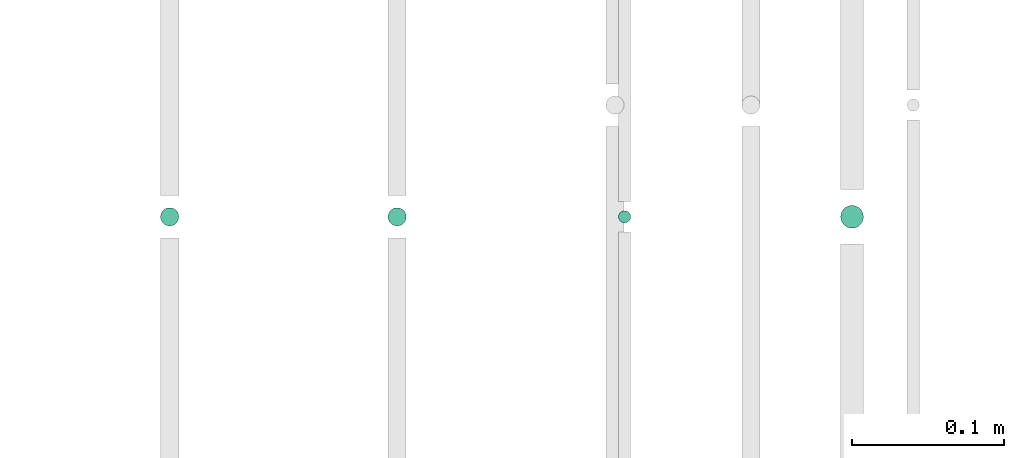
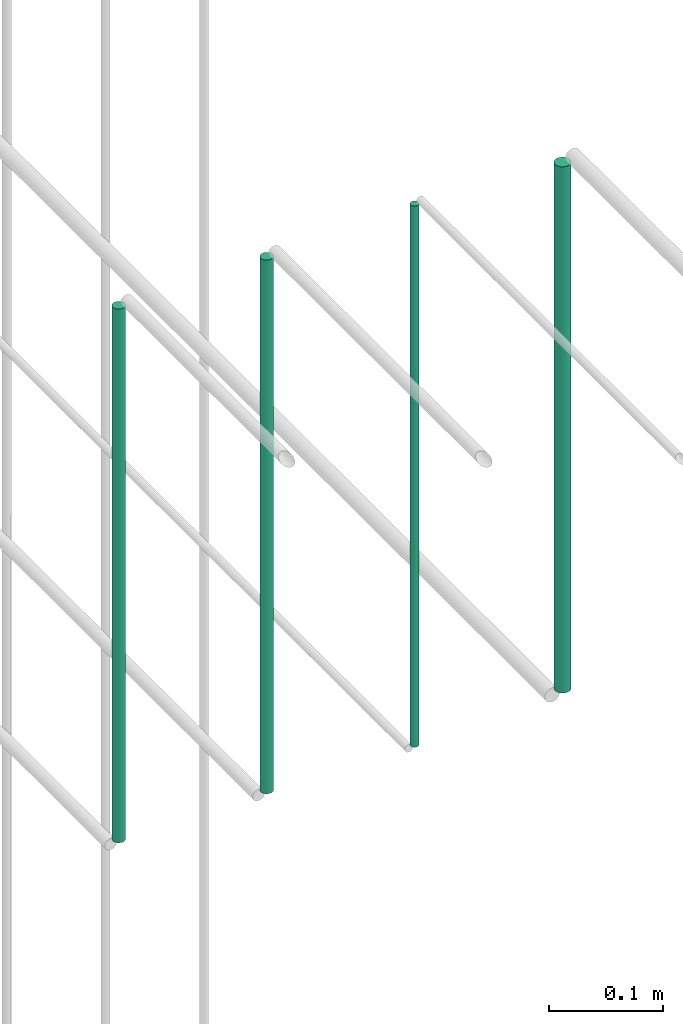
# One storey, part 215 of 331: 4 flow segments.
"""IFC2X3 building model written with IfcOpenShell, lengths in millimetres."""

import ifcopenshell
import ifcopenshell.guid

model = None  # the IFC model being written
_history = None  # IfcOwnerHistory: only IFC2X3 demands one
_inside = {}  # id of a spatial element -> (the spatial element, [elements in it])
_under = {}  # id of a project, library or spatial element -> (it, [spatial elements below it])
_declared = {}  # id of a project -> (the project, [libraries it declares])
_typed = {}  # id of a type object -> (the type object, [elements of that type])
_made_of = {}  # id of a material, layer set ... -> (it, [elements and type objects made of it])


def new_model(schema):
    """Start an empty IFC model of exactly this schema.

    Asked for "IFC4X3", IfcOpenShell would pick the latest addendum, in which some entities
    have other attributes; the version numbers below select the first issue.
    IFC2X3 requires an IfcOwnerHistory on every rooted entity: one is made here for all.
    """
    global model, _history
    if schema == "IFC4X3":
        model = ifcopenshell.file(schema_version=(4, 3, 0, 0))
    else:
        model = ifcopenshell.file(schema=schema)
    _inside.clear()
    _under.clear()
    _declared.clear()
    _typed.clear()
    _made_of.clear()
    _history = None
    if model.schema == "IFC2X3":
        org = make("IfcOrganization", Name="unknown")
        user = make(
            "IfcPersonAndOrganization",
            ThePerson=make("IfcPerson", FamilyName="unknown"),
            TheOrganization=org,
        )
        app = make(
            "IfcApplication",
            ApplicationDeveloper=org,
            Version="unknown",
            ApplicationFullName="unknown",
            ApplicationIdentifier="unknown",
        )
        _history = make(
            "IfcOwnerHistory",
            OwningUser=user,
            OwningApplication=app,
            ChangeAction="ADDED",
            CreationDate=0,
        )
    return model


def make(cls, **values):
    """One entity of the class cls with the attributes given. An attribute that is None is left unset."""
    return model.create_entity(
        cls, **{name: value for name, value in values.items() if value is not None}
    )


def entity(cls, *values):
    """Any entity or typed value of the class cls, its attributes in the order of the schema. None: left unset."""
    e = model.create_entity(cls)
    for i, value in enumerate(values):
        if value is not None:
            e[i] = value
    return e


def rooted(cls, **values):
    """An entity with a GlobalId (a new one), such as an element, a storey or a relation."""
    return make(cls, GlobalId=ifcopenshell.guid.new(), OwnerHistory=_history, **values)


def si_unit(unit_type, name, prefix=None):
    """IfcSIUnit, for example si_unit("LENGTHUNIT", "METRE", prefix="MILLI")."""
    return make("IfcSIUnit", UnitType=unit_type, Prefix=prefix, Name=name)


def converted_unit(unit_type, name, factor, base, dimensions=None, offset=None):
    """IfcConversionBasedUnit, such as the inch: factor (a typed value) times the base unit."""
    return make(
        "IfcConversionBasedUnit"
        if offset is None
        else "IfcConversionBasedUnitWithOffset",
        ConversionOffset=offset,
        Dimensions=None
        if dimensions is None
        else entity("IfcDimensionalExponents", *dimensions),
        UnitType=unit_type,
        Name=name,
        ConversionFactor=make(
            "IfcMeasureWithUnit", ValueComponent=factor, UnitComponent=base
        ),
    )


def derived_unit(unit_type, elements):
    """IfcDerivedUnit: a product of units, each with its exponent."""
    return make(
        "IfcDerivedUnit",
        Elements=[
            make("IfcDerivedUnitElement", Unit=unit, Exponent=power)
            for unit, power in elements
        ],
        UnitType=unit_type,
    )


def assignment(units):
    """IfcUnitAssignment: the units of a project."""
    return None if units is None else make("IfcUnitAssignment", Units=units)


def point(xyz):
    """IfcCartesianPoint."""
    return None if xyz is None else make("IfcCartesianPoint", Coordinates=xyz)


def direction(xyz):
    """IfcDirection."""
    return None if xyz is None else make("IfcDirection", DirectionRatios=xyz)


def frame(location, z_axis=None, x_axis=None):
    """IfcAxis2Placement3D, a coordinate frame: its origin and axes. An axis left out is left unset."""
    return make(
        "IfcAxis2Placement3D",
        Location=point(location),
        Axis=direction(z_axis),
        RefDirection=direction(x_axis),
    )


def frame_2d(location, x_axis=None):
    """IfcAxis2Placement2D, a coordinate frame in the plane: its origin and x axis."""
    return make(
        "IfcAxis2Placement2D", Location=point(location), RefDirection=direction(x_axis)
    )


def origin():
    """The frame at (0, 0, 0) with its axes left unset."""
    return frame((0.0, 0.0, 0.0))


def origin_2d_with_axis():
    """The frame at (0, 0) in the plane with the x axis (1, 0) written out."""
    return frame_2d((0.0, 0.0), x_axis=(1.0, 0.0))


def place(relative_to, where):
    """IfcLocalPlacement: puts the frame where relative to a parent placement (None: the world)."""
    return make(
        "IfcLocalPlacement", PlacementRelTo=relative_to, RelativePlacement=where
    )


def context(
    kind, dimensions, precision=None, world=None, true_north=None, identifier=None
):
    """IfcGeometricRepresentationContext, for example the 3D "Model" context."""
    return make(
        "IfcGeometricRepresentationContext",
        ContextIdentifier=identifier,
        ContextType=kind,
        CoordinateSpaceDimension=dimensions,
        Precision=precision,
        WorldCoordinateSystem=world,
        TrueNorth=true_north,
    )


def subcontext(parent, identifier, kind, view, scale=None):
    """IfcGeometricRepresentationSubContext, for example "Body" below "Model"."""
    return make(
        "IfcGeometricRepresentationSubContext",
        ContextIdentifier=identifier,
        ContextType=kind,
        ParentContext=parent,
        TargetScale=scale,
        TargetView=view,
    )


def project(units=None, contexts=None):
    """IfcProject with its units and contexts."""
    return rooted(
        "IfcProject",
        Name="project",
        RepresentationContexts=contexts,
        UnitsInContext=assignment(units),
    )


def spatial(cls, under=None, at=None, **own):
    """A site, building, storey or space (cls), placed at a placement, below another one or the project."""
    s = rooted(cls, ObjectPlacement=at, **own)
    if under is not None:
        _under.setdefault(under.id(), (under, []))[1].append(s)
    return s


def profile(cls, at=None, kind="AREA", **sizes):
    """A parametric profile (cls). Its sizes go by their IFC names, for example OverallWidth=200.0."""
    return make(cls, ProfileType=kind, Position=at, **sizes)


def circle(**sizes):
    """IfcCircleProfileDef."""
    return profile("IfcCircleProfileDef", **sizes)


def extrude(swept, where, along, depth):
    """IfcExtrudedAreaSolid: the profile swept, set in the frame where, extruded along a direction by depth."""
    return make(
        "IfcExtrudedAreaSolid",
        SweptArea=swept,
        Position=where,
        ExtrudedDirection=direction(along),
        Depth=depth,
    )


def shape(context_of_items, identifier, shape_type, items):
    """IfcShapeRepresentation: the items that make up one representation, for example the "Body"."""
    return make(
        "IfcShapeRepresentation",
        ContextOfItems=context_of_items,
        RepresentationIdentifier=identifier,
        RepresentationType=shape_type,
        Items=items,
    )


def made_of(thing, what):
    """Note that an element or type object is made of a material, layer set ...; save() writes the relation."""
    if what is not None:
        _made_of.setdefault(what.id(), (what, []))[1].append(thing)
    return thing


def type_object(cls, material=None, **own):
    """A type object (cls), such as IfcWallType, which elements share."""
    return made_of(rooted(cls, **own), material)


def element(
    cls,
    number,
    at=None,
    inside=None,
    cuts=None,
    type_object=None,
    material=None,
    context=None,
    identifier="Body",
    shape_type=None,
    held_by="IfcProductDefinitionShape",
    body=None,
    shapes=None,
    **own,
):
    """One element of the class cls, such as IfcWall. Its Tag is "e" and its number.

    at: its placement. inside: the storey or other place that contains it. cuts: it is an
    opening in that element (IfcRelVoidsElement). A single representation is given by context,
    identifier, shape_type and body (its items); several are given by shapes. held_by: the class
    of the entity that holds the representations. save() writes the other relations.
    """
    e = rooted(cls, Tag="e%d" % number, ObjectPlacement=at, **own)
    if body is not None:
        shapes = [shape(context, identifier, shape_type, body)]
    if shapes is not None:
        e.Representation = make(held_by, Representations=shapes)
    if inside is not None:
        _inside.setdefault(inside.id(), (inside, []))[1].append(e)
    if cuts is not None:
        rooted(
            "IfcRelVoidsElement", RelatingBuildingElement=cuts, RelatedOpeningElement=e
        )
    if type_object is not None:
        _typed.setdefault(type_object.id(), (type_object, []))[1].append(e)
    return made_of(e, material)


def aggregate(whole, parts):
    """IfcRelAggregates: a whole, such as a stair, and the parts it consists of."""
    return rooted("IfcRelAggregates", RelatingObject=whole, RelatedObjects=parts)


def save(model, path):
    """Write the relations noted so far, then the file.

    IfcRelAggregates (storeys below a building ...), IfcRelContainedInSpatialStructure (elements
    in a storey), IfcRelDefinesByType, IfcRelAssociatesMaterial and IfcRelDeclares: one each for
    every whole, place, type object, material and project.
    """
    for whole, parts in _under.values():
        aggregate(whole, parts)
    for where, things in _inside.values():
        rooted(
            "IfcRelContainedInSpatialStructure",
            RelatedElements=things,
            RelatingStructure=where,
        )
    for kind, things in _typed.values():
        rooted("IfcRelDefinesByType", RelatedObjects=things, RelatingType=kind)
    for what, things in _made_of.values():
        rooted("IfcRelAssociatesMaterial", RelatedObjects=things, RelatingMaterial=what)
    for by, libraries in _declared.values():
        rooted("IfcRelDeclares", RelatingContext=by, RelatedDefinitions=libraries)
    model.write(path)


model = new_model("IFC2X3")

# Units and contexts
model_context = context("Model", 3, precision=0.01, world=origin(), true_north=direction((6.12303176911189e-17, 1.0)))
body_context = subcontext(model_context, "Body", "Model", "MODEL_VIEW")
ifc_project = project(units=[si_unit("LENGTHUNIT", "METRE", prefix="MILLI"), si_unit("AREAUNIT", "SQUARE_METRE"), si_unit("VOLUMEUNIT", "CUBIC_METRE"), converted_unit("PLANEANGLEUNIT", "DEGREE", entity("IfcRatioMeasure", 0.0174532925199433), si_unit("PLANEANGLEUNIT", "RADIAN"), dimensions=[0, 0, 0, 0, 0, 0, 0]), si_unit("MASSUNIT", "GRAM", prefix="KILO"), derived_unit("MASSDENSITYUNIT", [(si_unit("MASSUNIT", "GRAM", prefix="KILO"), 1), (si_unit("LENGTHUNIT", "METRE"), -3)]), derived_unit("MOMENTOFINERTIAUNIT", [(si_unit("LENGTHUNIT", "METRE"), 4)]), si_unit("TIMEUNIT", "SECOND"), si_unit("FREQUENCYUNIT", "HERTZ"), si_unit("THERMODYNAMICTEMPERATUREUNIT", "DEGREE_CELSIUS"), derived_unit("THERMALTRANSMITTANCEUNIT", [(si_unit("MASSUNIT", "GRAM", prefix="KILO"), 1), (si_unit("THERMODYNAMICTEMPERATUREUNIT", "KELVIN"), -1), (si_unit("TIMEUNIT", "SECOND"), -3)]), derived_unit("VOLUMETRICFLOWRATEUNIT", [(si_unit("LENGTHUNIT", "METRE"), 3), (si_unit("TIMEUNIT", "SECOND"), -1)]), derived_unit("MASSFLOWRATEUNIT", [(si_unit("MASSUNIT", "GRAM", prefix="KILO"), 1), (si_unit("TIMEUNIT", "SECOND"), -1)]), derived_unit("ROTATIONALFREQUENCYUNIT", [(si_unit("TIMEUNIT", "SECOND"), -1)]), si_unit("ELECTRICCURRENTUNIT", "AMPERE"), si_unit("ELECTRICVOLTAGEUNIT", "VOLT"), si_unit("POWERUNIT", "WATT"), si_unit("FORCEUNIT", "NEWTON", prefix="KILO"), si_unit("ILLUMINANCEUNIT", "LUX"), si_unit("LUMINOUSFLUXUNIT", "LUMEN"), si_unit("LUMINOUSINTENSITYUNIT", "CANDELA"), derived_unit("USERDEFINED", [(si_unit("MASSUNIT", "GRAM", prefix="KILO"), -1), (si_unit("LENGTHUNIT", "METRE"), -2), (si_unit("TIMEUNIT", "SECOND"), 3), (si_unit("LUMINOUSFLUXUNIT", "LUMEN"), 1)]), derived_unit("LINEARVELOCITYUNIT", [(si_unit("LENGTHUNIT", "METRE"), 1), (si_unit("TIMEUNIT", "SECOND"), -1)]), si_unit("PRESSUREUNIT", "PASCAL"), derived_unit("USERDEFINED", [(si_unit("LENGTHUNIT", "METRE"), -2), (si_unit("MASSUNIT", "GRAM", prefix="KILO"), 1), (si_unit("TIMEUNIT", "SECOND"), -2)]), derived_unit("LINEARFORCEUNIT", [(si_unit("MASSUNIT", "GRAM", prefix="KILO"), 1), (si_unit("LENGTHUNIT", "METRE"), 1), (si_unit("TIMEUNIT", "SECOND"), -2), (si_unit("LENGTHUNIT", "METRE"), -1)]), derived_unit("PLANARFORCEUNIT", [(si_unit("MASSUNIT", "GRAM", prefix="KILO"), 1), (si_unit("LENGTHUNIT", "METRE"), 1), (si_unit("TIMEUNIT", "SECOND"), -2), (si_unit("LENGTHUNIT", "METRE"), -2)])], contexts=[model_context])

# Site, building, storey
site_placement = place(None, frame((0.0, -0.00077364408347762, 0.0)))
site = spatial("IfcSite", under=ifc_project, at=site_placement, CompositionType="ELEMENT")
building_placement = place(site_placement, origin())
building = spatial("IfcBuilding", under=site, at=building_placement, CompositionType="ELEMENT")
storey_placement = place(building_placement, origin())
storey = spatial("IfcBuildingStorey", under=building, at=storey_placement, CompositionType="ELEMENT", Elevation=0.0)

# Flow segments
pipe_segment_type = type_object("IfcPipeSegmentType", PredefinedType="NOTDEFINED")
flow_segment_1_placement = place(storey_placement, frame((62968.5166110417, 5562.34830470758, 18464.0)))
element("IfcFlowSegment", 1, at=flow_segment_1_placement, inside=storey, type_object=pipe_segment_type, context=body_context, shape_type="SweptSolid", body=[
    extrude(circle(Radius=6.0, at=origin_2d_with_axis()), frame((7.59527223591454, 7.59527223591562, 0.0), z_axis=(0.0, 0.0, 1.0), x_axis=(-1.0, 0.0, 0.0)), (0.0, 0.0, 1.0), 572.000000000013),
])
flow_segment_2_placement = place(storey_placement, frame((63118.5166110417, 5562.34830470758, 18464.0)))
element("IfcFlowSegment", 2, at=flow_segment_2_placement, inside=storey, type_object=pipe_segment_type, context=body_context, shape_type="SweptSolid", body=[
    extrude(circle(Radius=6.0, at=origin_2d_with_axis()), frame((7.59527223591454, 7.59527223591562, 0.0), z_axis=(0.0, 0.0, 1.0), x_axis=(-1.0, 0.0, 0.0)), (0.0, 0.0, 1.0), 571.999999998378),
])
flow_segment_3_placement = place(storey_placement, frame((63270.5166110417, 5564.34830470758, 18460.0)))
element("IfcFlowSegment", 3, at=flow_segment_3_placement, inside=storey, type_object=pipe_segment_type, context=body_context, shape_type="SweptSolid", body=[
    extrude(circle(Radius=4.0, at=origin_2d_with_axis()), frame((5.59527223591499, 5.59527223591607, 0.0), z_axis=(0.0, 0.0, 1.0), x_axis=(-1.0, 0.0, 0.0)), (0.0, 0.0, 1.0), 579.999999994911),
])
flow_segment_4_placement = place(storey_placement, frame((63417.0166110417, 5560.84830470758, 18468.0)))
element("IfcFlowSegment", 4, at=flow_segment_4_placement, inside=storey, type_object=pipe_segment_type, context=body_context, shape_type="SweptSolid", body=[
    extrude(circle(Radius=7.5, at=origin_2d_with_axis()), frame((9.09527223591419, 9.09527223591636, 0.0), z_axis=(0.0, 0.0, 1.0), x_axis=(-1.0, 0.0, 0.0)), (0.0, 0.0, 1.0), 564.000000000013),
])

save(model, "model.ifc")
